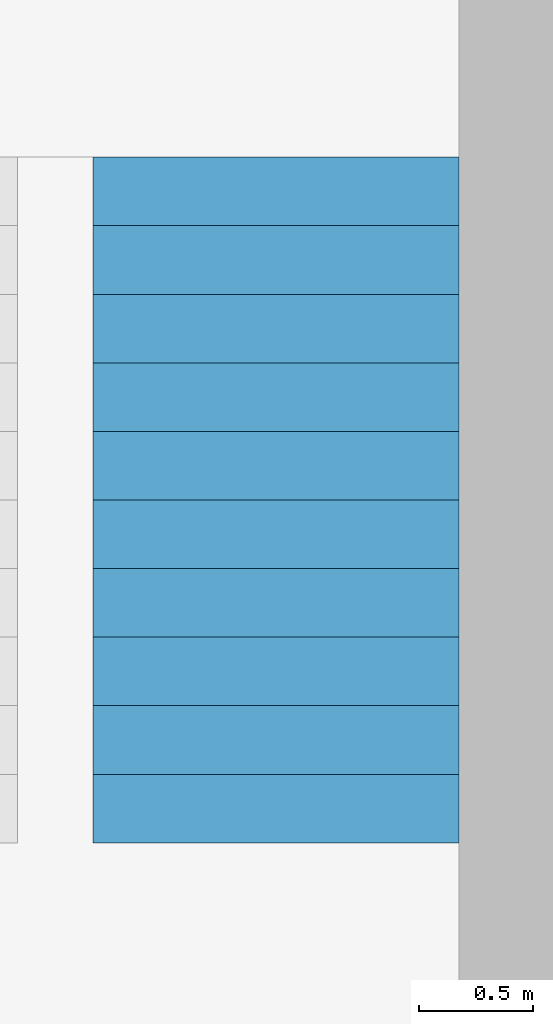
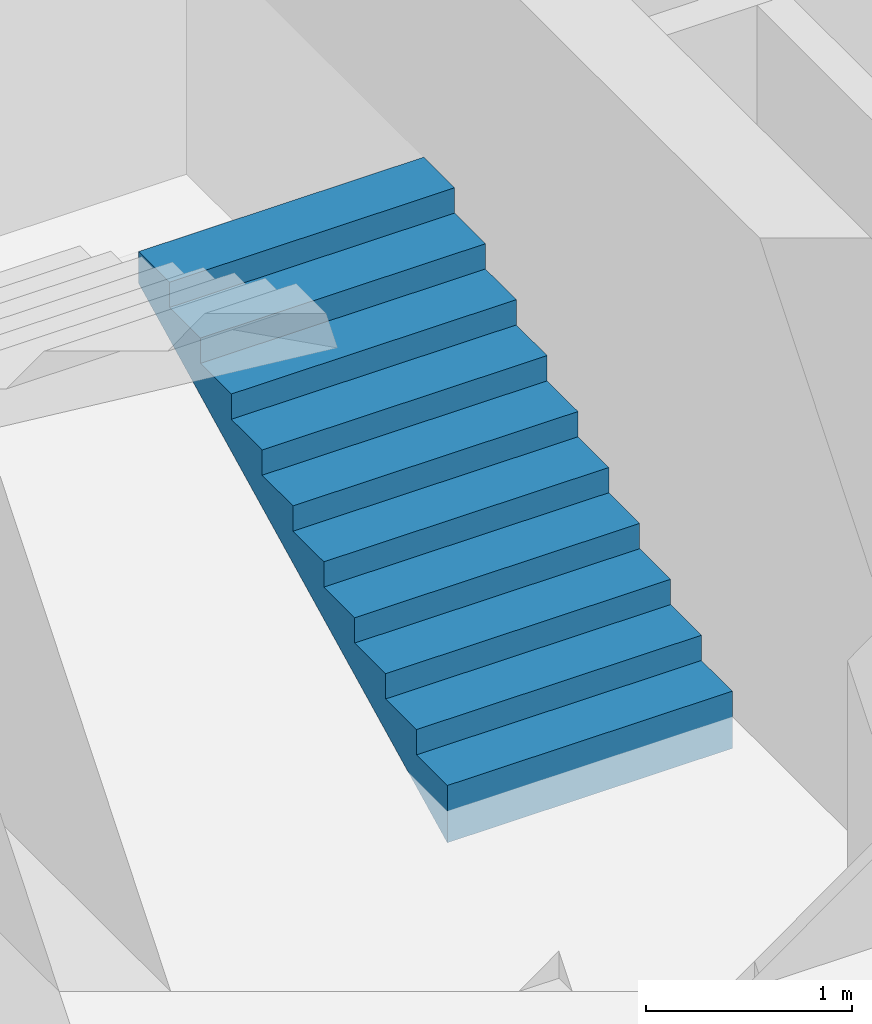
# One storey, part 3 of 5: 1 building element part, 1 element without a shape of its own.
"""IFC4 building model written with IfcOpenShell, lengths in metres."""

import ifcopenshell
import ifcopenshell.guid

model = None  # the IFC model being written
_history = None  # IfcOwnerHistory: only IFC2X3 demands one
_inside = {}  # id of a spatial element -> (the spatial element, [elements in it])
_under = {}  # id of a project, library or spatial element -> (it, [spatial elements below it])
_declared = {}  # id of a project -> (the project, [libraries it declares])
_typed = {}  # id of a type object -> (the type object, [elements of that type])
_made_of = {}  # id of a material, layer set ... -> (it, [elements and type objects made of it])


def new_model(schema):
    """Start an empty IFC model of exactly this schema.

    Asked for "IFC4X3", IfcOpenShell would pick the latest addendum, in which some entities
    have other attributes; the version numbers below select the first issue.
    IFC2X3 requires an IfcOwnerHistory on every rooted entity: one is made here for all.
    """
    global model, _history
    if schema == "IFC4X3":
        model = ifcopenshell.file(schema_version=(4, 3, 0, 0))
    else:
        model = ifcopenshell.file(schema=schema)
    _inside.clear()
    _under.clear()
    _declared.clear()
    _typed.clear()
    _made_of.clear()
    _history = None
    if model.schema == "IFC2X3":
        org = make("IfcOrganization", Name="unknown")
        user = make(
            "IfcPersonAndOrganization",
            ThePerson=make("IfcPerson", FamilyName="unknown"),
            TheOrganization=org,
        )
        app = make(
            "IfcApplication",
            ApplicationDeveloper=org,
            Version="unknown",
            ApplicationFullName="unknown",
            ApplicationIdentifier="unknown",
        )
        _history = make(
            "IfcOwnerHistory",
            OwningUser=user,
            OwningApplication=app,
            ChangeAction="ADDED",
            CreationDate=0,
        )
    return model


def make(cls, **values):
    """One entity of the class cls with the attributes given. An attribute that is None is left unset."""
    return model.create_entity(
        cls, **{name: value for name, value in values.items() if value is not None}
    )


def entity(cls, *values):
    """Any entity or typed value of the class cls, its attributes in the order of the schema. None: left unset."""
    e = model.create_entity(cls)
    for i, value in enumerate(values):
        if value is not None:
            e[i] = value
    return e


def rooted(cls, **values):
    """An entity with a GlobalId (a new one), such as an element, a storey or a relation."""
    return make(cls, GlobalId=ifcopenshell.guid.new(), OwnerHistory=_history, **values)


def si_unit(unit_type, name, prefix=None):
    """IfcSIUnit, for example si_unit("LENGTHUNIT", "METRE", prefix="MILLI")."""
    return make("IfcSIUnit", UnitType=unit_type, Prefix=prefix, Name=name)


def converted_unit(unit_type, name, factor, base, dimensions=None, offset=None):
    """IfcConversionBasedUnit, such as the inch: factor (a typed value) times the base unit."""
    return make(
        "IfcConversionBasedUnit"
        if offset is None
        else "IfcConversionBasedUnitWithOffset",
        ConversionOffset=offset,
        Dimensions=None
        if dimensions is None
        else entity("IfcDimensionalExponents", *dimensions),
        UnitType=unit_type,
        Name=name,
        ConversionFactor=make(
            "IfcMeasureWithUnit", ValueComponent=factor, UnitComponent=base
        ),
    )


def derived_unit(unit_type, elements):
    """IfcDerivedUnit: a product of units, each with its exponent."""
    return make(
        "IfcDerivedUnit",
        Elements=[
            make("IfcDerivedUnitElement", Unit=unit, Exponent=power)
            for unit, power in elements
        ],
        UnitType=unit_type,
    )


def assignment(units):
    """IfcUnitAssignment: the units of a project."""
    return None if units is None else make("IfcUnitAssignment", Units=units)


def point(xyz):
    """IfcCartesianPoint."""
    return None if xyz is None else make("IfcCartesianPoint", Coordinates=xyz)


def direction(xyz):
    """IfcDirection."""
    return None if xyz is None else make("IfcDirection", DirectionRatios=xyz)


def frame(location, z_axis=None, x_axis=None):
    """IfcAxis2Placement3D, a coordinate frame: its origin and axes. An axis left out is left unset."""
    return make(
        "IfcAxis2Placement3D",
        Location=point(location),
        Axis=direction(z_axis),
        RefDirection=direction(x_axis),
    )


def origin_with_axes():
    """The frame at (0, 0, 0) with the z axis (0, 0, 1) and the x axis (1, 0, 0) written out."""
    return frame((0.0, 0.0, 0.0), z_axis=(0.0, 0.0, 1.0), x_axis=(1.0, 0.0, 0.0))


def place(relative_to, where):
    """IfcLocalPlacement: puts the frame where relative to a parent placement (None: the world)."""
    return make(
        "IfcLocalPlacement", PlacementRelTo=relative_to, RelativePlacement=where
    )


def context(
    kind, dimensions, precision=None, world=None, true_north=None, identifier=None
):
    """IfcGeometricRepresentationContext, for example the 3D "Model" context."""
    return make(
        "IfcGeometricRepresentationContext",
        ContextIdentifier=identifier,
        ContextType=kind,
        CoordinateSpaceDimension=dimensions,
        Precision=precision,
        WorldCoordinateSystem=world,
        TrueNorth=true_north,
    )


def subcontext(parent, identifier, kind, view, scale=None):
    """IfcGeometricRepresentationSubContext, for example "Body" below "Model"."""
    return make(
        "IfcGeometricRepresentationSubContext",
        ContextIdentifier=identifier,
        ContextType=kind,
        ParentContext=parent,
        TargetScale=scale,
        TargetView=view,
    )


def project(units=None, contexts=None):
    """IfcProject with its units and contexts."""
    return rooted(
        "IfcProject",
        Name="project",
        RepresentationContexts=contexts,
        UnitsInContext=assignment(units),
    )


def spatial(cls, under=None, at=None, **own):
    """A site, building, storey or space (cls), placed at a placement, below another one or the project."""
    s = rooted(cls, ObjectPlacement=at, **own)
    if under is not None:
        _under.setdefault(under.id(), (under, []))[1].append(s)
    return s


def point_list(points):
    """IfcCartesianPointList2D or 3D."""
    cls = (
        "IfcCartesianPointList2D" if len(points[0]) == 2 else "IfcCartesianPointList3D"
    )
    return make(cls, CoordList=points)


def polygons(points, faces, closed=None, point_numbers=None):
    """IfcPolygonalFaceSet: a face is its outer loop, then its inner loops; points numbered from 1."""
    made = []
    for loops in faces:
        if len(loops) == 1:
            made.append(make("IfcIndexedPolygonalFace", CoordIndex=loops[0]))
        else:
            made.append(
                make(
                    "IfcIndexedPolygonalFaceWithVoids",
                    CoordIndex=loops[0],
                    InnerCoordIndices=loops[1:],
                )
            )
    return make(
        "IfcPolygonalFaceSet",
        Coordinates=point_list(points),
        Closed=closed,
        Faces=made,
        PnIndex=point_numbers,
    )


def shape(context_of_items, identifier, shape_type, items):
    """IfcShapeRepresentation: the items that make up one representation, for example the "Body"."""
    return make(
        "IfcShapeRepresentation",
        ContextOfItems=context_of_items,
        RepresentationIdentifier=identifier,
        RepresentationType=shape_type,
        Items=items,
    )


def material(Name=None, Category=None):
    """IfcMaterial."""
    return make("IfcMaterial", Name=Name, Category=Category)


def made_of(thing, what):
    """Note that an element or type object is made of a material, layer set ...; save() writes the relation."""
    if what is not None:
        _made_of.setdefault(what.id(), (what, []))[1].append(thing)
    return thing


def type_object(cls, material=None, **own):
    """A type object (cls), such as IfcWallType, which elements share."""
    return made_of(rooted(cls, **own), material)


def element(
    cls,
    number,
    at=None,
    inside=None,
    cuts=None,
    type_object=None,
    material=None,
    context=None,
    identifier="Body",
    shape_type=None,
    held_by="IfcProductDefinitionShape",
    body=None,
    shapes=None,
    **own,
):
    """One element of the class cls, such as IfcWall. Its Tag is "e" and its number.

    at: its placement. inside: the storey or other place that contains it. cuts: it is an
    opening in that element (IfcRelVoidsElement). A single representation is given by context,
    identifier, shape_type and body (its items); several are given by shapes. held_by: the class
    of the entity that holds the representations. save() writes the other relations.
    """
    e = rooted(cls, Tag="e%d" % number, ObjectPlacement=at, **own)
    if body is not None:
        shapes = [shape(context, identifier, shape_type, body)]
    if shapes is not None:
        e.Representation = make(held_by, Representations=shapes)
    if inside is not None:
        _inside.setdefault(inside.id(), (inside, []))[1].append(e)
    if cuts is not None:
        rooted(
            "IfcRelVoidsElement", RelatingBuildingElement=cuts, RelatedOpeningElement=e
        )
    if type_object is not None:
        _typed.setdefault(type_object.id(), (type_object, []))[1].append(e)
    return made_of(e, material)


def aggregate(whole, parts):
    """IfcRelAggregates: a whole, such as a stair, and the parts it consists of."""
    return rooted("IfcRelAggregates", RelatingObject=whole, RelatedObjects=parts)


def save(model, path):
    """Write the relations noted so far, then the file.

    IfcRelAggregates (storeys below a building ...), IfcRelContainedInSpatialStructure (elements
    in a storey), IfcRelDefinesByType, IfcRelAssociatesMaterial and IfcRelDeclares: one each for
    every whole, place, type object, material and project.
    """
    for whole, parts in _under.values():
        aggregate(whole, parts)
    for where, things in _inside.values():
        rooted(
            "IfcRelContainedInSpatialStructure",
            RelatedElements=things,
            RelatingStructure=where,
        )
    for kind, things in _typed.values():
        rooted("IfcRelDefinesByType", RelatedObjects=things, RelatingType=kind)
    for what, things in _made_of.values():
        rooted("IfcRelAssociatesMaterial", RelatedObjects=things, RelatingMaterial=what)
    for by, libraries in _declared.values():
        rooted("IfcRelDeclares", RelatingContext=by, RelatedDefinitions=libraries)
    model.write(path)


model = new_model("IFC4")

# Units and contexts
model_context = context("Model", 3, precision=1e-05, world=origin_with_axes(), true_north=direction((0.0, 1.0)))
body_context = subcontext(model_context, "Body", "Model", "MODEL_VIEW")
ifc_project = project(units=[si_unit("LENGTHUNIT", "METRE"), si_unit("AREAUNIT", "SQUARE_METRE"), si_unit("VOLUMEUNIT", "CUBIC_METRE"), converted_unit("PLANEANGLEUNIT", "DEGREE", entity("IfcPlaneAngleMeasure", 0.0174532925199433), si_unit("PLANEANGLEUNIT", "RADIAN"), dimensions=[0, 0, 0, 0, 0, 0, 0]), converted_unit("TIMEUNIT", "Year", entity("IfcTimeMeasure", 31557600.0), si_unit("TIMEUNIT", "SECOND"), dimensions=[0, 0, 1, 0, 0, 0, 0]), si_unit("MASSUNIT", "GRAM", prefix="KILO"), si_unit("THERMODYNAMICTEMPERATUREUNIT", "DEGREE_CELSIUS"), si_unit("LUMINOUSINTENSITYUNIT", "LUMEN"), si_unit("ENERGYUNIT", "JOULE", prefix="MEGA"), derived_unit("THERMALCONDUCTANCEUNIT", [(si_unit("POWERUNIT", "WATT"), 1), (si_unit("LENGTHUNIT", "METRE"), -1), (si_unit("THERMODYNAMICTEMPERATUREUNIT", "KELVIN"), -1)]), derived_unit("SPECIFICHEATCAPACITYUNIT", [(si_unit("ENERGYUNIT", "JOULE"), 1), (si_unit("MASSUNIT", "GRAM", prefix="KILO"), -1), (si_unit("THERMODYNAMICTEMPERATUREUNIT", "KELVIN"), -1)]), derived_unit("MASSDENSITYUNIT", [(si_unit("MASSUNIT", "GRAM", prefix="KILO"), 1), (si_unit("VOLUMEUNIT", "CUBIC_METRE"), -1)])], contexts=[model_context])

# Site, building, storey
site_placement = place(None, origin_with_axes())
site = spatial("IfcSite", under=ifc_project, at=site_placement, CompositionType="ELEMENT")
building_placement = place(site_placement, origin_with_axes())
building = spatial("IfcBuilding", under=site, at=building_placement, CompositionType="ELEMENT")
storey_placement = place(building_placement, frame((0.0, 0.0, -3.0), z_axis=(0.0, 0.0, 1.0), x_axis=(1.0, 0.0, 0.0)))
storey = spatial("IfcBuildingStorey", under=building, at=storey_placement, Name="UG", CompositionType="ELEMENT", Elevation=-3.0)

# Stair, building element part
stair_type = type_object("IfcStairType", PredefinedType="NOTDEFINED")
stair_placement = place(storey_placement, frame((26.388, 9.024999945467552, 0.0), z_axis=(0.0, 0.0, 1.0), x_axis=(1.0, 0.0, 0.0)))
stair = element("IfcStair", 1, at=stair_placement, inside=storey, type_object=stair_type, Name="Treppe - 003", PredefinedType="NOTDEFINED")
ifc_material = material(Name="Stahlbeton Decke")
building_element_part_placement = place(stair_placement, origin_with_axes())
building_element_part = element("IfcBuildingElementPart", 2, at=building_element_part_placement, material=ifc_material, Name="Stahlbeton Decke", PredefinedType="NOTDEFINED", context=body_context, shape_type="Tessellation", body=[
    polygons([(1.6, 2.774999999999999, 1.197434221912518), (1.6, 2.85, 1.234934221912518), (1.6, 2.925000000000001, 1.272434221912518), (1.6, 3.000000000000001, 1.309934221912518), (1.6, 3.000000000000001, 1.5), (1.6, 2.699999999999999, 1.5), (1.6, 2.699999999999999, 1.35), (1.6, 2.399999999999999, 1.35), (1.6, 2.399999999999999, 1.2), (1.6, 2.1, 1.2), (1.6, 2.1, 1.05), (1.6, 1.8, 1.05), (1.6, 1.8, 0.9000000000000001), (1.6, 1.5, 0.8999999999999999), (1.6, 1.5, 0.75), (1.6, 1.2, 0.75), (1.6, 1.2, 0.6000000000000001), (1.6, 0.8999999999999994, 0.6000000000000001), (1.6, 0.8999999999999994, 0.45), (1.6, 0.5999999999999996, 0.45), (1.6, 0.5999999999999996, 0.3), (1.6, 0.2999999999999998, 0.3), (1.6, 0.2999999999999998, 0.1499999999999999), (1.6, 0.0, 0.1499999999999999), (1.6, 0.0, -0.1900657780874822), (1.6, 0.09999999999999987, -0.1400657780874821), (1.6, 0.2, -0.09006577808748206), (1.6, 0.2999999999999998, -0.04006577808748224), (1.6, 0.3999999999999999, 0.009934221912517804), (1.6, 0.4999999999999998, 0.05993422191251785), (1.6, 0.5999999999999996, 0.1099342219125177), (1.6, 0.6999999999999995, 0.1599342219125177), (1.6, 0.7999999999999996, 0.2099342219125178), (1.6, 0.8999999999999994, 0.2599342219125178), (1.6, 0.9749999999999995, 0.2974342219125179), (1.6, 1.05, 0.3349342219125178), (1.6, 1.125, 0.3724342219125178), (1.6, 1.2, 0.4099342219125179), (1.6, 1.275, 0.4474342219125178), (1.6, 1.35, 0.4849342219125179), (1.6, 1.425, 0.5224342219125178), (1.6, 1.5, 0.5599342219125177), (1.6, 1.575, 0.5974342219125177), (1.6, 1.65, 0.6349342219125178), (1.6, 1.725, 0.6724342219125179), (1.6, 1.8, 0.7099342219125179), (1.6, 1.9, 0.7599342219125179), (1.6, 2.0, 0.8099342219125178), (1.6, 2.1, 0.8599342219125179), (1.6, 2.2, 0.9099342219125178), (1.6, 2.299999999999999, 0.9599342219125175), (1.6, 2.399999999999999, 1.009934221912518), (1.6, 2.5, 1.059934221912518), (1.6, 2.599999999999999, 1.109934221912517), (1.6, 2.699999999999999, 1.159934221912518), (0.0, 2.774999999999999, 1.197434221912518), (0.0, 2.85, 1.234934221912518), (0.0, 2.925000000000001, 1.272434221912518), (0.0, 3.000000000000001, 1.309934221912518), (0.0, 3.000000000000001, 1.5), (0.0, 2.699999999999999, 1.5), (0.0, 2.699999999999999, 1.35), (0.0, 2.399999999999999, 1.35), (0.0, 2.399999999999999, 1.2), (0.0, 2.1, 1.2), (0.0, 2.1, 1.05), (0.0, 1.8, 1.05), (0.0, 1.8, 0.8999999999999999), (0.0, 1.5, 0.8999999999999999), (0.0, 1.5, 0.75), (0.0, 1.2, 0.75), (0.0, 1.2, 0.6000000000000001), (0.0, 0.8999999999999994, 0.6000000000000001), (0.0, 0.8999999999999994, 0.45), (0.0, 0.5999999999999996, 0.45), (0.0, 0.5999999999999996, 0.2999999999999998), (0.0, 0.2999999999999998, 0.3), (0.0, 0.2999999999999998, 0.1499999999999999), (0.0, 0.0, 0.1499999999999999), (0.0, 0.0, -0.1900657780874822), (0.0, 0.09999999999999987, -0.1400657780874821), (0.0, 0.2, -0.09006577808748206), (0.0, 0.2999999999999998, -0.04006577808748224), (0.0, 0.3999999999999999, 0.009934221912517804), (0.0, 0.4999999999999998, 0.05993422191251785), (0.0, 0.5999999999999996, 0.1099342219125177), (0.0, 0.6999999999999995, 0.1599342219125177), (0.0, 0.7999999999999996, 0.2099342219125178), (0.0, 0.8999999999999994, 0.2599342219125178), (0.0, 0.9749999999999995, 0.2974342219125179), (0.0, 1.05, 0.3349342219125178), (0.0, 1.125, 0.3724342219125178), (0.0, 1.2, 0.4099342219125179), (0.0, 1.275, 0.4474342219125178), (0.0, 1.35, 0.4849342219125179), (0.0, 1.425, 0.5224342219125178), (0.0, 1.5, 0.5599342219125177), (0.0, 1.575, 0.5974342219125177), (0.0, 1.65, 0.6349342219125178), (0.0, 1.725, 0.6724342219125179), (0.0, 1.8, 0.7099342219125179), (0.0, 1.9, 0.7599342219125179), (0.0, 2.0, 0.8099342219125178), (0.0, 2.1, 0.8599342219125179), (0.0, 2.2, 0.9099342219125178), (0.0, 2.299999999999999, 0.9599342219125175), (0.0, 2.399999999999999, 1.009934221912518), (0.0, 2.5, 1.059934221912518), (0.0, 2.599999999999999, 1.109934221912517), (0.0, 2.699999999999999, 1.159934221912518)], [[[1, 2, 3, 4, 5, 6, 7, 8, 9, 10, 11, 12, 13, 14, 15, 16, 17, 18, 19, 20, 21, 22, 23, 24, 25, 26, 27, 28, 29, 30, 31, 32, 33, 34, 35, 36, 37, 38, 39, 40, 41, 42, 43, 44, 45, 46, 47, 48, 49, 50, 51, 52, 53, 54, 55]], [[56, 57, 2, 1]], [[57, 58, 3, 2]], [[58, 59, 4, 3]], [[5, 4, 59, 60]], [[5, 60, 61, 6]], [[61, 62, 7, 6]], [[62, 63, 8, 7]], [[9, 8, 63, 64]], [[64, 65, 10, 9]], [[11, 10, 65, 66]], [[66, 67, 12, 11]], [[13, 12, 67, 68]], [[68, 69, 14, 13]], [[15, 14, 69, 70]], [[70, 71, 16, 15]], [[17, 16, 71, 72]], [[72, 73, 18, 17]], [[19, 18, 73, 74]], [[74, 75, 20, 19]], [[21, 20, 75, 76]], [[76, 77, 22, 21]], [[23, 22, 77, 78]], [[78, 79, 24, 23]], [[24, 79, 80, 25]], [[80, 81, 26, 25]], [[81, 82, 27, 26]], [[82, 83, 28, 27]], [[83, 84, 29, 28]], [[84, 85, 30, 29]], [[85, 86, 31, 30]], [[86, 87, 32, 31]], [[87, 88, 33, 32]], [[88, 89, 34, 33]], [[89, 90, 35, 34]], [[90, 91, 36, 35]], [[91, 92, 37, 36]], [[92, 93, 38, 37]], [[93, 94, 39, 38]], [[94, 95, 40, 39]], [[95, 96, 41, 40]], [[96, 97, 42, 41]], [[97, 98, 43, 42]], [[98, 99, 44, 43]], [[99, 100, 45, 44]], [[100, 101, 46, 45]], [[101, 102, 47, 46]], [[102, 103, 48, 47]], [[103, 104, 49, 48]], [[104, 105, 50, 49]], [[105, 106, 51, 50]], [[106, 107, 52, 51]], [[107, 108, 53, 52]], [[108, 109, 54, 53]], [[109, 110, 55, 54]], [[110, 56, 1, 55]], [[83, 82, 81, 80, 79, 78, 77, 76, 75, 74, 73, 72, 71, 70, 69, 68, 67, 66, 65, 64, 63, 62, 61, 60, 59, 58, 57, 56, 110, 109, 108, 107, 106, 105, 104, 103, 102, 101, 100, 99, 98, 97, 96, 95, 94, 93, 92, 91, 90, 89, 88, 87, 86, 85, 84]]], closed=True),
])
aggregate(stair, [building_element_part])

save(model, "model.ifc")
